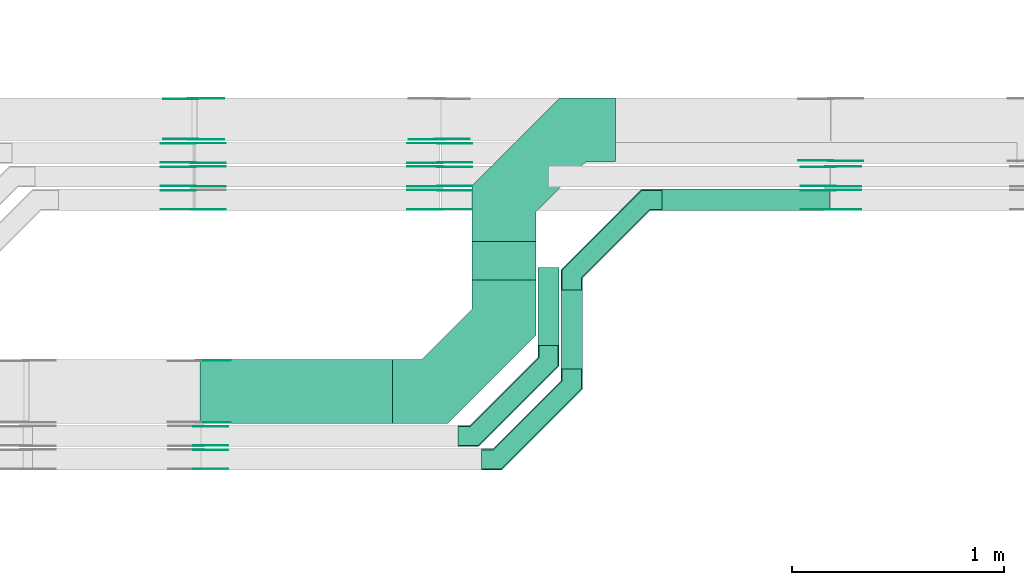
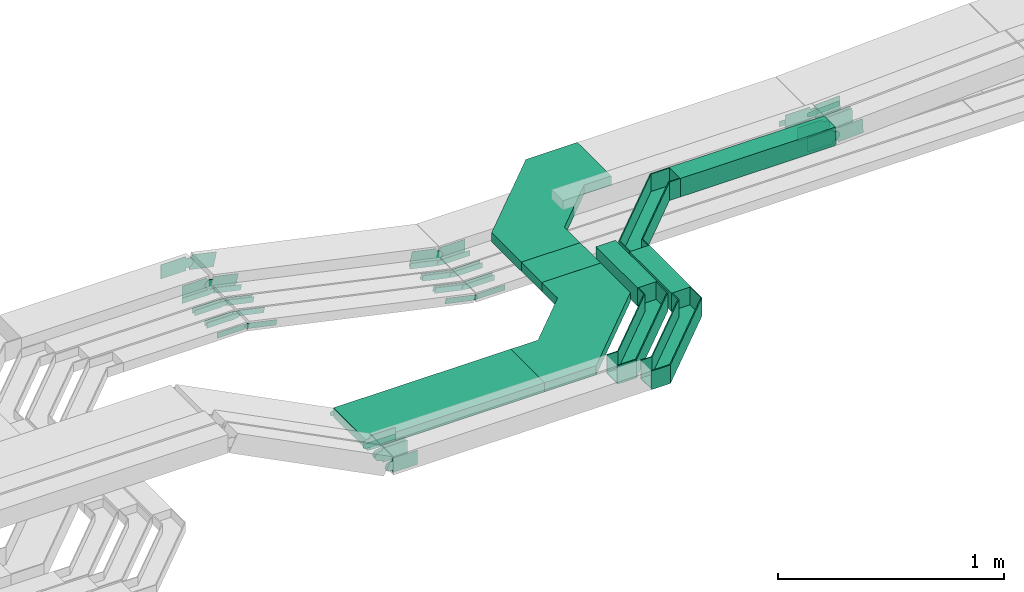
# One storey, part 15 of 32: 50 flow fittings, 5 flow segments.
"""IFC2X3 building model written with IfcOpenShell, lengths in millimetres."""

import ifcopenshell
import ifcopenshell.guid

model = None  # the IFC model being written
_history = None  # IfcOwnerHistory: only IFC2X3 demands one
_inside = {}  # id of a spatial element -> (the spatial element, [elements in it])
_under = {}  # id of a project, library or spatial element -> (it, [spatial elements below it])
_declared = {}  # id of a project -> (the project, [libraries it declares])
_typed = {}  # id of a type object -> (the type object, [elements of that type])
_made_of = {}  # id of a material, layer set ... -> (it, [elements and type objects made of it])


def new_model(schema):
    """Start an empty IFC model of exactly this schema.

    Asked for "IFC4X3", IfcOpenShell would pick the latest addendum, in which some entities
    have other attributes; the version numbers below select the first issue.
    IFC2X3 requires an IfcOwnerHistory on every rooted entity: one is made here for all.
    """
    global model, _history
    if schema == "IFC4X3":
        model = ifcopenshell.file(schema_version=(4, 3, 0, 0))
    else:
        model = ifcopenshell.file(schema=schema)
    _inside.clear()
    _under.clear()
    _declared.clear()
    _typed.clear()
    _made_of.clear()
    _history = None
    if model.schema == "IFC2X3":
        org = make("IfcOrganization", Name="unknown")
        user = make(
            "IfcPersonAndOrganization",
            ThePerson=make("IfcPerson", FamilyName="unknown"),
            TheOrganization=org,
        )
        app = make(
            "IfcApplication",
            ApplicationDeveloper=org,
            Version="unknown",
            ApplicationFullName="unknown",
            ApplicationIdentifier="unknown",
        )
        _history = make(
            "IfcOwnerHistory",
            OwningUser=user,
            OwningApplication=app,
            ChangeAction="ADDED",
            CreationDate=0,
        )
    return model


def make(cls, **values):
    """One entity of the class cls with the attributes given. An attribute that is None is left unset."""
    return model.create_entity(
        cls, **{name: value for name, value in values.items() if value is not None}
    )


def entity(cls, *values):
    """Any entity or typed value of the class cls, its attributes in the order of the schema. None: left unset."""
    e = model.create_entity(cls)
    for i, value in enumerate(values):
        if value is not None:
            e[i] = value
    return e


def rooted(cls, **values):
    """An entity with a GlobalId (a new one), such as an element, a storey or a relation."""
    return make(cls, GlobalId=ifcopenshell.guid.new(), OwnerHistory=_history, **values)


def si_unit(unit_type, name, prefix=None):
    """IfcSIUnit, for example si_unit("LENGTHUNIT", "METRE", prefix="MILLI")."""
    return make("IfcSIUnit", UnitType=unit_type, Prefix=prefix, Name=name)


def converted_unit(unit_type, name, factor, base, dimensions=None, offset=None):
    """IfcConversionBasedUnit, such as the inch: factor (a typed value) times the base unit."""
    return make(
        "IfcConversionBasedUnit"
        if offset is None
        else "IfcConversionBasedUnitWithOffset",
        ConversionOffset=offset,
        Dimensions=None
        if dimensions is None
        else entity("IfcDimensionalExponents", *dimensions),
        UnitType=unit_type,
        Name=name,
        ConversionFactor=make(
            "IfcMeasureWithUnit", ValueComponent=factor, UnitComponent=base
        ),
    )


def derived_unit(unit_type, elements):
    """IfcDerivedUnit: a product of units, each with its exponent."""
    return make(
        "IfcDerivedUnit",
        Elements=[
            make("IfcDerivedUnitElement", Unit=unit, Exponent=power)
            for unit, power in elements
        ],
        UnitType=unit_type,
    )


def assignment(units):
    """IfcUnitAssignment: the units of a project."""
    return None if units is None else make("IfcUnitAssignment", Units=units)


def point(xyz):
    """IfcCartesianPoint."""
    return None if xyz is None else make("IfcCartesianPoint", Coordinates=xyz)


def direction(xyz):
    """IfcDirection."""
    return None if xyz is None else make("IfcDirection", DirectionRatios=xyz)


def frame(location, z_axis=None, x_axis=None):
    """IfcAxis2Placement3D, a coordinate frame: its origin and axes. An axis left out is left unset."""
    return make(
        "IfcAxis2Placement3D",
        Location=point(location),
        Axis=direction(z_axis),
        RefDirection=direction(x_axis),
    )


def frame_2d(location, x_axis=None):
    """IfcAxis2Placement2D, a coordinate frame in the plane: its origin and x axis."""
    return make(
        "IfcAxis2Placement2D", Location=point(location), RefDirection=direction(x_axis)
    )


def origin():
    """The frame at (0, 0, 0) with its axes left unset."""
    return frame((0.0, 0.0, 0.0))


def origin_2d_with_axis():
    """The frame at (0, 0) in the plane with the x axis (1, 0) written out."""
    return frame_2d((0.0, 0.0), x_axis=(1.0, 0.0))


def place(relative_to, where):
    """IfcLocalPlacement: puts the frame where relative to a parent placement (None: the world)."""
    return make(
        "IfcLocalPlacement", PlacementRelTo=relative_to, RelativePlacement=where
    )


def context(
    kind, dimensions, precision=None, world=None, true_north=None, identifier=None
):
    """IfcGeometricRepresentationContext, for example the 3D "Model" context."""
    return make(
        "IfcGeometricRepresentationContext",
        ContextIdentifier=identifier,
        ContextType=kind,
        CoordinateSpaceDimension=dimensions,
        Precision=precision,
        WorldCoordinateSystem=world,
        TrueNorth=true_north,
    )


def subcontext(parent, identifier, kind, view, scale=None):
    """IfcGeometricRepresentationSubContext, for example "Body" below "Model"."""
    return make(
        "IfcGeometricRepresentationSubContext",
        ContextIdentifier=identifier,
        ContextType=kind,
        ParentContext=parent,
        TargetScale=scale,
        TargetView=view,
    )


def project(units=None, contexts=None):
    """IfcProject with its units and contexts."""
    return rooted(
        "IfcProject",
        Name="project",
        RepresentationContexts=contexts,
        UnitsInContext=assignment(units),
    )


def spatial(cls, under=None, at=None, **own):
    """A site, building, storey or space (cls), placed at a placement, below another one or the project."""
    s = rooted(cls, ObjectPlacement=at, **own)
    if under is not None:
        _under.setdefault(under.id(), (under, []))[1].append(s)
    return s


def polyline(points):
    """IfcPolyline through the points."""
    return make("IfcPolyline", Points=[point(p) for p in points])


def circle_curve(where, radius):
    """IfcCircle in the frame where."""
    return make("IfcCircle", Position=where, Radius=radius)


def parameter(value):
    """IfcParameterValue: where a trimmed curve begins or ends, as a parameter of its basis curve."""
    return model.create_entity("IfcParameterValue", value)


def trimmed(basis, trim1, trim2, sense, master):
    """IfcTrimmedCurve: the piece of a basis curve between two trims."""
    return make(
        "IfcTrimmedCurve",
        BasisCurve=basis,
        Trim1=trim1,
        Trim2=trim2,
        SenseAgreement=sense,
        MasterRepresentation=master,
    )


def segment(curve, same_sense, transition):
    """IfcCompositeCurveSegment."""
    return make(
        "IfcCompositeCurveSegment",
        Transition=transition,
        SameSense=same_sense,
        ParentCurve=curve,
    )


def composite_curve(segments, self_intersect=None):
    """IfcCompositeCurve: segments joined end to end."""
    return make("IfcCompositeCurve", Segments=segments, SelfIntersect=self_intersect)


def profile(cls, at=None, kind="AREA", **sizes):
    """A parametric profile (cls). Its sizes go by their IFC names, for example OverallWidth=200.0."""
    return make(cls, ProfileType=kind, Position=at, **sizes)


def rectangle(**sizes):
    """IfcRectangleProfileDef."""
    return profile("IfcRectangleProfileDef", **sizes)


def outline(outer, holes=None, kind="AREA"):
    """IfcArbitraryClosedProfileDef: a profile drawn as a closed curve; with holes, ...WithVoids."""
    if holes is None:
        return make("IfcArbitraryClosedProfileDef", ProfileType=kind, OuterCurve=outer)
    return make(
        "IfcArbitraryProfileDefWithVoids",
        ProfileType=kind,
        OuterCurve=outer,
        InnerCurves=holes,
    )


def extrude(swept, where, along, depth):
    """IfcExtrudedAreaSolid: the profile swept, set in the frame where, extruded along a direction by depth."""
    return make(
        "IfcExtrudedAreaSolid",
        SweptArea=swept,
        Position=where,
        ExtrudedDirection=direction(along),
        Depth=depth,
    )


def faces_of(points, faces, orient=None, outer=None):
    """IfcFace entities. A face is a list of loops; a loop is a list of indices into points, from 0.

    orient and outer hold one flag for each loop. By default every Orientation is true, the
    first loop of a face is its IfcFaceOuterBound and the others are IfcFaceBound.
    """
    made = []
    for i, loops in enumerate(faces):
        bounds = []
        for j, loop in enumerate(loops):
            is_outer = j == 0 if outer is None else outer[i][j]
            bounds.append(
                make(
                    "IfcFaceOuterBound" if is_outer else "IfcFaceBound",
                    Bound=make("IfcPolyLoop", Polygon=[points[k] for k in loop]),
                    Orientation=True if orient is None else orient[i][j],
                )
            )
        made.append(make("IfcFace", Bounds=bounds))
    return made


def faceted_brep(points, faces, orient=None, outer=None, voids=None):
    """IfcFacetedBrep: a solid bounded by flat faces; with voids (closed shells), ...WithVoids."""
    shared = [point(p) for p in points]
    hull = make("IfcClosedShell", CfsFaces=faces_of(shared, faces, orient, outer))
    if voids is None:
        return make("IfcFacetedBrep", Outer=hull)
    return make(
        "IfcFacetedBrepWithVoids",
        Outer=hull,
        Voids=[
            make(cls, CfsFaces=faces_of(shared, fs, o, b)) for cls, fs, o, b in voids
        ],
    )


def shape(context_of_items, identifier, shape_type, items):
    """IfcShapeRepresentation: the items that make up one representation, for example the "Body"."""
    return make(
        "IfcShapeRepresentation",
        ContextOfItems=context_of_items,
        RepresentationIdentifier=identifier,
        RepresentationType=shape_type,
        Items=items,
    )


def source(mapping_origin, context_of_items, identifier, shape_type, items):
    """IfcRepresentationMap: a shape defined once, which mapped items show again and again."""
    return make(
        "IfcRepresentationMap",
        MappingOrigin=mapping_origin,
        MappedRepresentation=shape(context_of_items, identifier, shape_type, items),
    )


def transform(
    local_origin,
    x_axis=None,
    y_axis=None,
    z_axis=None,
    scale=None,
    scale2=None,
    scale3=None,
    uniform=True,
):
    """IfcCartesianTransformationOperator3D, or its non-uniform kind. x_axis, y_axis, z_axis: its Axis1, 2, 3."""
    if uniform:
        return make(
            "IfcCartesianTransformationOperator3D",
            Axis1=direction(x_axis),
            Axis2=direction(y_axis),
            LocalOrigin=point(local_origin),
            Scale=scale,
            Axis3=direction(z_axis),
        )
    return make(
        "IfcCartesianTransformationOperator3DnonUniform",
        Axis1=direction(x_axis),
        Axis2=direction(y_axis),
        LocalOrigin=point(local_origin),
        Scale=scale,
        Axis3=direction(z_axis),
        Scale2=scale2,
        Scale3=scale3,
    )


def mapped(mapping_source, mapping_target):
    """IfcMappedItem: shows the shape of a source again, moved by a transform."""
    return make(
        "IfcMappedItem", MappingSource=mapping_source, MappingTarget=mapping_target
    )


def material(Name=None, Category=None):
    """IfcMaterial."""
    return make("IfcMaterial", Name=Name, Category=Category)


def made_of(thing, what):
    """Note that an element or type object is made of a material, layer set ...; save() writes the relation."""
    if what is not None:
        _made_of.setdefault(what.id(), (what, []))[1].append(thing)
    return thing


def type_object(cls, material=None, **own):
    """A type object (cls), such as IfcWallType, which elements share."""
    return made_of(rooted(cls, **own), material)


def type_shapes(of_type, sources):
    """Give a type object the sources (RepresentationMaps) that its elements show as mapped items."""
    of_type.RepresentationMaps = sources


def element(
    cls,
    number,
    at=None,
    inside=None,
    cuts=None,
    type_object=None,
    material=None,
    context=None,
    identifier="Body",
    shape_type=None,
    held_by="IfcProductDefinitionShape",
    body=None,
    shapes=None,
    **own,
):
    """One element of the class cls, such as IfcWall. Its Tag is "e" and its number.

    at: its placement. inside: the storey or other place that contains it. cuts: it is an
    opening in that element (IfcRelVoidsElement). A single representation is given by context,
    identifier, shape_type and body (its items); several are given by shapes. held_by: the class
    of the entity that holds the representations. save() writes the other relations.
    """
    e = rooted(cls, Tag="e%d" % number, ObjectPlacement=at, **own)
    if body is not None:
        shapes = [shape(context, identifier, shape_type, body)]
    if shapes is not None:
        e.Representation = make(held_by, Representations=shapes)
    if inside is not None:
        _inside.setdefault(inside.id(), (inside, []))[1].append(e)
    if cuts is not None:
        rooted(
            "IfcRelVoidsElement", RelatingBuildingElement=cuts, RelatedOpeningElement=e
        )
    if type_object is not None:
        _typed.setdefault(type_object.id(), (type_object, []))[1].append(e)
    return made_of(e, material)


def aggregate(whole, parts):
    """IfcRelAggregates: a whole, such as a stair, and the parts it consists of."""
    return rooted("IfcRelAggregates", RelatingObject=whole, RelatedObjects=parts)


def save(model, path):
    """Write the relations noted so far, then the file.

    IfcRelAggregates (storeys below a building ...), IfcRelContainedInSpatialStructure (elements
    in a storey), IfcRelDefinesByType, IfcRelAssociatesMaterial and IfcRelDeclares: one each for
    every whole, place, type object, material and project.
    """
    for whole, parts in _under.values():
        aggregate(whole, parts)
    for where, things in _inside.values():
        rooted(
            "IfcRelContainedInSpatialStructure",
            RelatedElements=things,
            RelatingStructure=where,
        )
    for kind, things in _typed.values():
        rooted("IfcRelDefinesByType", RelatedObjects=things, RelatingType=kind)
    for what, things in _made_of.values():
        rooted("IfcRelAssociatesMaterial", RelatedObjects=things, RelatingMaterial=what)
    for by, libraries in _declared.values():
        rooted("IfcRelDeclares", RelatingContext=by, RelatedDefinitions=libraries)
    model.write(path)


model = new_model("IFC2X3")

# Units and contexts
model_context = context("Model", 3, precision=0.01, world=origin(), true_north=direction((6.12303176911189e-17, 1.0)))
body_context = subcontext(model_context, "Body", "Model", "MODEL_VIEW")
ifc_project = project(units=[si_unit("LENGTHUNIT", "METRE", prefix="MILLI"), si_unit("AREAUNIT", "SQUARE_METRE"), si_unit("VOLUMEUNIT", "CUBIC_METRE"), converted_unit("PLANEANGLEUNIT", "DEGREE", entity("IfcRatioMeasure", 0.0174532925199433), si_unit("PLANEANGLEUNIT", "RADIAN"), dimensions=[0, 0, 0, 0, 0, 0, 0]), si_unit("MASSUNIT", "GRAM", prefix="KILO"), derived_unit("MASSDENSITYUNIT", [(si_unit("MASSUNIT", "GRAM", prefix="KILO"), 1), (si_unit("LENGTHUNIT", "METRE"), -3)]), derived_unit("MOMENTOFINERTIAUNIT", [(si_unit("LENGTHUNIT", "METRE"), 4)]), si_unit("TIMEUNIT", "SECOND"), si_unit("FREQUENCYUNIT", "HERTZ"), si_unit("THERMODYNAMICTEMPERATUREUNIT", "DEGREE_CELSIUS"), derived_unit("THERMALTRANSMITTANCEUNIT", [(si_unit("MASSUNIT", "GRAM", prefix="KILO"), 1), (si_unit("THERMODYNAMICTEMPERATUREUNIT", "KELVIN"), -1), (si_unit("TIMEUNIT", "SECOND"), -3)]), derived_unit("VOLUMETRICFLOWRATEUNIT", [(si_unit("LENGTHUNIT", "METRE"), 3), (si_unit("TIMEUNIT", "SECOND"), -1)]), derived_unit("MASSFLOWRATEUNIT", [(si_unit("MASSUNIT", "GRAM", prefix="KILO"), 1), (si_unit("TIMEUNIT", "SECOND"), -1)]), derived_unit("ROTATIONALFREQUENCYUNIT", [(si_unit("TIMEUNIT", "SECOND"), -1)]), si_unit("ELECTRICCURRENTUNIT", "AMPERE"), si_unit("ELECTRICVOLTAGEUNIT", "VOLT"), si_unit("POWERUNIT", "WATT"), si_unit("FORCEUNIT", "NEWTON", prefix="KILO"), si_unit("ILLUMINANCEUNIT", "LUX"), si_unit("LUMINOUSFLUXUNIT", "LUMEN"), si_unit("LUMINOUSINTENSITYUNIT", "CANDELA"), derived_unit("USERDEFINED", [(si_unit("MASSUNIT", "GRAM", prefix="KILO"), -1), (si_unit("LENGTHUNIT", "METRE"), -2), (si_unit("TIMEUNIT", "SECOND"), 3), (si_unit("LUMINOUSFLUXUNIT", "LUMEN"), 1)]), derived_unit("LINEARVELOCITYUNIT", [(si_unit("LENGTHUNIT", "METRE"), 1), (si_unit("TIMEUNIT", "SECOND"), -1)]), si_unit("PRESSUREUNIT", "PASCAL"), derived_unit("USERDEFINED", [(si_unit("LENGTHUNIT", "METRE"), -2), (si_unit("MASSUNIT", "GRAM", prefix="KILO"), 1), (si_unit("TIMEUNIT", "SECOND"), -2)]), derived_unit("LINEARFORCEUNIT", [(si_unit("MASSUNIT", "GRAM", prefix="KILO"), 1), (si_unit("LENGTHUNIT", "METRE"), 1), (si_unit("TIMEUNIT", "SECOND"), -2), (si_unit("LENGTHUNIT", "METRE"), -1)]), derived_unit("PLANARFORCEUNIT", [(si_unit("MASSUNIT", "GRAM", prefix="KILO"), 1), (si_unit("LENGTHUNIT", "METRE"), 1), (si_unit("TIMEUNIT", "SECOND"), -2), (si_unit("LENGTHUNIT", "METRE"), -2)])], contexts=[model_context])

# Site, building, storey
site_placement = place(None, origin())
site = spatial("IfcSite", under=ifc_project, at=site_placement, CompositionType="ELEMENT")
building_placement = place(site_placement, origin())
building = spatial("IfcBuilding", under=site, at=building_placement, CompositionType="ELEMENT")
storey_placement = place(building_placement, frame((0.0, 0.0, 8100.0)))
storey = spatial("IfcBuildingStorey", under=building, at=storey_placement, CompositionType="ELEMENT", Elevation=8100.0)

# Flow segments
cable_carrier_segment_type = type_object("IfcCableCarrierSegmentType", PredefinedType="CABLETRAYSEGMENT")
flow_segment_1_placement = place(storey_placement, frame((34739.92, 9645.0, 2749.28)))
element("IfcFlowSegment", 1, at=flow_segment_1_placement, inside=storey, type_object=cable_carrier_segment_type, context=body_context, shape_type="SweptSolid", body=[
    extrude(rectangle(XDim=791.634197765681, YDim=100.000000000001, at=origin_2d_with_axis()), frame((395.82, 50.0, 0.0)), (0.0, 0.0, 1.0), 99.9999999999989),
])
flow_segment_2_placement = place(storey_placement, frame((32562.96, 8642.05, 2750.02)))
element("IfcFlowSegment", 2, at=flow_segment_2_placement, inside=storey, type_object=cable_carrier_segment_type, context=body_context, shape_type="SweptSolid", body=[
    extrude(rectangle(XDim=905.362974416974, YDim=300.000000000001, at=origin_2d_with_axis()), frame((452.68, 150.0, 0.0)), (0.0, 0.0, 1.0), 50.0000000000016),
])
flow_segment_3_placement = place(storey_placement, frame((33844.32, 9318.05, 2750.02)))
element("IfcFlowSegment", 3, at=flow_segment_3_placement, inside=storey, type_object=cable_carrier_segment_type, context=body_context, shape_type="SweptSolid", body=[
    extrude(rectangle(XDim=180.951872357372, YDim=300.000000000001, at=origin_2d_with_axis()), frame((150.0, 90.48, 0.0), z_axis=(0.0, 0.0, 1.0), x_axis=(0.0, 1.0, 0.0)), (0.0, 0.0, 1.0), 49.9999999999995),
])
flow_segment_4_placement = place(storey_placement, frame((34153.92, 9008.45, 2750.01)))
element("IfcFlowSegment", 4, at=flow_segment_4_placement, inside=storey, type_object=cable_carrier_segment_type, context=body_context, shape_type="SweptSolid", body=[
    extrude(rectangle(XDim=366.546732922404, YDim=100.000000000003, at=origin_2d_with_axis()), frame((50.0, 183.27, 0.0), z_axis=(0.0, 0.0, 1.0), x_axis=(0.0, 1.0, 0.0)), (0.0, 0.0, 1.0), 99.9999999999968),
])
flow_segment_5_placement = place(storey_placement, frame((34263.92, 8898.45, 2749.28)))
element("IfcFlowSegment", 5, at=flow_segment_5_placement, inside=storey, type_object=cable_carrier_segment_type, context=body_context, shape_type="SweptSolid", body=[
    extrude(rectangle(XDim=370.546732922424, YDim=100.000000000003, at=origin_2d_with_axis()), frame((50.0, 185.27, 0.0), z_axis=(0.0, 0.0, 1.0), x_axis=(0.0, 1.0, 0.0)), (0.0, 0.0, 1.0), 99.9999999999989),
])

# Flow fittings
ifc_material_1 = material()
cable_carrier_fitting_type_1 = type_object("IfcCableCarrierFittingType", Name="470_DKC_G5_Sheet horizontal bend:-", PredefinedType="NOTDEFINED", material=ifc_material_1)
shared_shape_1 = source(origin(), body_context, "Body", "SweptSolid", [
    extrude(outline(polyline([(-313.25, -362.75), (-50.12, -362.75), (362.75, 50.12), (362.75, 313.25), (62.75, 313.25), (62.75, 174.38), (-174.38, -62.75), (-313.25, -62.75), (-313.25, -362.75)])), frame((-212.75, 212.75, -25.0)), (0.0, 0.0, 1.0), 50.0000000000003),
])
type_shapes(cable_carrier_fitting_type_1, [shared_shape_1])
flow_fitting_1_placement = place(storey_placement, frame((33994.32, 8792.05, 2775.02)))
element("IfcFlowFitting", 6, at=flow_fitting_1_placement, inside=storey, type_object=cable_carrier_fitting_type_1, material=ifc_material_1, Name="470_DKC_G5_Sheet horizontal bend:-", ObjectType="470_DKC_G5_Sheet horizontal bend:-", context=body_context, shape_type="MappedRepresentation", body=[
    mapped(shared_shape_1, transform((0.0, 0.0, 0.0), scale=1.0)),
])
flow_fitting_2_placement = place(storey_placement, frame((33994.32, 10025.0, 2775.02), z_axis=(0.0, 0.0, 1.0), x_axis=(-1.0, 0.0, 0.0)))
element("IfcFlowFitting", 7, at=flow_fitting_2_placement, inside=storey, type_object=cable_carrier_fitting_type_1, material=ifc_material_1, Name="470_DKC_G5_Sheet horizontal bend:-", ObjectType="470_DKC_G5_Sheet horizontal bend:-", context=body_context, shape_type="MappedRepresentation", body=[
    mapped(shared_shape_1, transform((0.0, 0.0, 0.0), scale=1.0)),
])
cable_carrier_fitting_type_2 = type_object("IfcCableCarrierFittingType", Name="470_DKC_G5_Sheet horizontal bend:-", PredefinedType="NOTDEFINED", material=ifc_material_1)
shared_shape_2 = source(origin(), body_context, "Body", "Brep", [
    faceted_brep([(-426.0, -50.0, -50.0), (-426.0, -50.0, 50.0), (-426.0, -45.0, 50.0), (-426.0, -45.0, -45.0), (-426.0, 45.0, -45.0), (-426.0, 45.0, 50.0), (-426.0, 50.0, 50.0), (-426.0, 50.0, -50.0), (50.0, 426.0, -50.0), (-50.0, 426.0, -50.0), (-50.0, 426.0, 50.0), (-45.0, 426.0, 50.0), (-45.0, 426.0, -45.0), (45.0, 426.0, -45.0), (45.0, 426.0, 50.0), (50.0, 426.0, 50.0), (-329.29, -50.0, -50.0), (-329.29, -50.0, 50.0), (50.0, 329.29, 50.0), (45.0, 331.36, 50.0), (-331.36, -45.0, 50.0), (-331.36, -45.0, -45.0), (45.0, 331.36, -45.0), (-45.0, 368.64, -45.0), (-368.64, 45.0, -45.0), (-368.64, 45.0, 50.0), (-45.0, 368.64, 50.0), (-50.0, 370.71, 50.0), (-370.71, 50.0, 50.0), (-370.71, 50.0, -50.0), (-50.0, 370.71, -50.0), (50.0, 329.29, -50.0)], [[[0, 1, 2, 3, 4, 5, 6, 7]], [[8, 9, 10, 11, 12, 13, 14, 15]], [[1, 0, 16, 17]], [[2, 1, 17, 18, 15, 14, 19, 20]], [[3, 2, 20, 21]], [[4, 3, 21, 22, 13, 12, 23, 24]], [[5, 4, 24, 25]], [[6, 5, 25, 26, 11, 10, 27, 28]], [[7, 6, 28, 29]], [[0, 7, 29, 30, 9, 8, 31, 16]], [[17, 16, 31, 18]], [[21, 20, 19, 22]], [[25, 24, 23, 26]], [[29, 28, 27, 30]], [[18, 31, 8, 15]], [[22, 19, 14, 13]], [[26, 23, 12, 11]], [[30, 27, 10, 9]]]),
])
type_shapes(cable_carrier_fitting_type_2, [shared_shape_2])
for number, where, name in (
    (8, (34203.92, 8582.45, 2800.01), "470_DKC_G5_Sheet horizontal bend:-"),
    (9, (34313.92, 8472.45, 2799.28), "470_DKC_G5_Sheet horizontal bend:-"),
):
    element("IfcFlowFitting", number, at=place(storey_placement, frame(where)), inside=storey, type_object=cable_carrier_fitting_type_2, material=ifc_material_1, Name=name, ObjectType="470_DKC_G5_Sheet horizontal bend:-", context=body_context, shape_type="MappedRepresentation", body=[
        mapped(shared_shape_2, transform((0.0, 0.0, 0.0), scale=1.0)),
    ])
flow_fitting_3_placement = place(storey_placement, frame((34313.92, 9695.0, 2799.28), z_axis=(0.0, 0.0, 1.0), x_axis=(-1.0, 0.0, 0.0)))
element("IfcFlowFitting", 10, at=flow_fitting_3_placement, inside=storey, type_object=cable_carrier_fitting_type_2, material=ifc_material_1, Name="470_DKC_G5_Sheet horizontal bend:-", ObjectType="470_DKC_G5_Sheet horizontal bend:-", context=body_context, shape_type="MappedRepresentation", body=[
    mapped(shared_shape_2, transform((0.0, 0.0, 0.0), scale=1.0)),
])
ifc_material_2 = material(Name="G")
cable_carrier_fitting_type_3 = type_object("IfcCableCarrierFittingType", PredefinedType="NOTDEFINED", material=ifc_material_2)
shared_shape_3 = source(origin(), body_context, "Body", "SweptSolid", [
    extrude(outline(composite_curve([segment(trimmed(circle_curve(frame_2d((-44.59, 0.0), x_axis=(1.0, 0.0)), 12.5), [parameter(90.0000000000007)], [parameter(270.0)], True, "PARAMETER"), True, "CONTINUOUS"), segment(polyline([(-44.59, -12.5), (-33.09, -12.5)]), True, "CONTINUOUS"), segment(polyline([(-33.09, -12.5), (-31.23, -14.5)]), True, "CONTINUOUS"), segment(polyline([(-31.23, -14.5), (108.91, -14.5)]), True, "CONTINUOUS"), segment(polyline([(108.91, -14.5), (108.91, 14.5)]), True, "CONTINUOUS"), segment(polyline([(108.91, 14.5), (-31.23, 14.5)]), True, "CONTINUOUS"), segment(polyline([(-31.23, 14.5), (-33.09, 12.5)]), True, "CONTINUOUS"), segment(polyline([(-33.09, 12.5), (-44.59, 12.5)]), True, "CONTINUOUS")], self_intersect=False)), frame((44.59, 0.0, 0.0), z_axis=(0.0, 0.0, -1.0), x_axis=(1.0, 0.0, 0.0)), (0.0, 0.0, -1.0), 2.0),
])
type_shapes(cable_carrier_fitting_type_3, [shared_shape_3])
flow_fitting_4_placement = place(storey_placement, frame((33692.72, 9740.46, 2571.63), z_axis=(0.0, 1.0, 0.0), x_axis=(-0.977059422663225, 0.0, 0.212966862645354)))
element("IfcFlowFitting", 11, at=flow_fitting_4_placement, inside=storey, type_object=cable_carrier_fitting_type_3, material=ifc_material_2, context=body_context, shape_type="MappedRepresentation", body=[
    mapped(shared_shape_3, transform((0.0, 0.0, 0.0), scale=1.0)),
])
cable_carrier_fitting_type_4 = type_object("IfcCableCarrierFittingType", PredefinedType="NOTDEFINED", material=ifc_material_2)
type_shapes(cable_carrier_fitting_type_4, [shared_shape_3])
for number, where, z_axis, x_axis in (
    (12, (33692.72, 9651.54, 2571.63), (0.0, -1.0, 0.0), (1.0, 0.0, 0.0)),
    (13, (32530.31, 9651.54, 2825.0), (0.0, -1.0, 0.0), (-1.0, 0.0, 0.0)),
):
    element("IfcFlowFitting", number, at=place(storey_placement, frame(where, z_axis=z_axis, x_axis=x_axis)), inside=storey, type_object=cable_carrier_fitting_type_4, material=ifc_material_2, context=body_context, shape_type="MappedRepresentation", body=[
        mapped(shared_shape_3, transform((0.0, 0.0, 0.0), scale=1.0)),
    ])
flow_fitting_5_placement = place(storey_placement, frame((33692.72, 9850.46, 2571.32), z_axis=(0.0, 1.0, 0.0), x_axis=(-0.977004473697579, 0.0, 0.21321880398998)))
element("IfcFlowFitting", 14, at=flow_fitting_5_placement, inside=storey, type_object=cable_carrier_fitting_type_3, material=ifc_material_2, context=body_context, shape_type="MappedRepresentation", body=[
    mapped(shared_shape_3, transform((0.0, 0.0, 0.0), scale=1.0)),
])
flow_fitting_6_placement = place(storey_placement, frame((33692.72, 9761.54, 2571.32), z_axis=(0.0, -1.0, 0.0), x_axis=(1.0, 0.0, 0.0)))
element("IfcFlowFitting", 15, at=flow_fitting_6_placement, inside=storey, type_object=cable_carrier_fitting_type_4, material=ifc_material_2, context=body_context, shape_type="MappedRepresentation", body=[
    mapped(shared_shape_3, transform((0.0, 0.0, 0.0), scale=1.0)),
])
flow_fitting_7_placement = place(storey_placement, frame((32530.31, 9850.46, 2825.0), z_axis=(0.0, 1.0, 0.0), x_axis=(0.977004473697579, 0.0, -0.21321880398998)))
element("IfcFlowFitting", 16, at=flow_fitting_7_placement, inside=storey, type_object=cable_carrier_fitting_type_3, material=ifc_material_2, context=body_context, shape_type="MappedRepresentation", body=[
    mapped(shared_shape_3, transform((0.0, 0.0, 0.0), scale=1.0)),
])
flow_fitting_8_placement = place(storey_placement, frame((32530.31, 9761.54, 2825.0), z_axis=(0.0, -1.0, 0.0), x_axis=(-1.0, 0.0, 0.0)))
element("IfcFlowFitting", 17, at=flow_fitting_8_placement, inside=storey, type_object=cable_carrier_fitting_type_4, material=ifc_material_2, context=body_context, shape_type="MappedRepresentation", body=[
    mapped(shared_shape_3, transform((0.0, 0.0, 0.0), scale=1.0)),
])
flow_fitting_9_placement = place(storey_placement, frame((33692.72, 9960.46, 2569.93), z_axis=(0.0, 1.0, 0.0), x_axis=(-0.976759892794402, 0.0, 0.214336445403643)))
element("IfcFlowFitting", 18, at=flow_fitting_9_placement, inside=storey, type_object=cable_carrier_fitting_type_3, material=ifc_material_2, context=body_context, shape_type="MappedRepresentation", body=[
    mapped(shared_shape_3, transform((0.0, 0.0, 0.0), scale=1.0)),
])
flow_fitting_10_placement = place(storey_placement, frame((33692.72, 9871.54, 2569.93), z_axis=(0.0, -1.0, 0.0), x_axis=(1.0, 0.0, 0.0)))
element("IfcFlowFitting", 19, at=flow_fitting_10_placement, inside=storey, type_object=cable_carrier_fitting_type_4, material=ifc_material_2, context=body_context, shape_type="MappedRepresentation", body=[
    mapped(shared_shape_3, transform((0.0, 0.0, 0.0), scale=1.0)),
])
flow_fitting_11_placement = place(storey_placement, frame((32530.31, 9960.46, 2825.0), z_axis=(0.0, 1.0, 0.0), x_axis=(0.976759892794402, 0.0, -0.214336445403643)))
element("IfcFlowFitting", 20, at=flow_fitting_11_placement, inside=storey, type_object=cable_carrier_fitting_type_3, material=ifc_material_2, context=body_context, shape_type="MappedRepresentation", body=[
    mapped(shared_shape_3, transform((0.0, 0.0, 0.0), scale=1.0)),
])
flow_fitting_12_placement = place(storey_placement, frame((32530.31, 9871.54, 2825.0), z_axis=(0.0, -1.0, 0.0), x_axis=(-1.0, 0.0, 0.0)))
element("IfcFlowFitting", 21, at=flow_fitting_12_placement, inside=storey, type_object=cable_carrier_fitting_type_4, material=ifc_material_2, context=body_context, shape_type="MappedRepresentation", body=[
    mapped(shared_shape_3, transform((0.0, 0.0, 0.0), scale=1.0)),
])
for number, where, z_axis, x_axis in (
    (22, (32555.01, 8646.59, 2775.02), (0.0, -1.0, 0.0), (1.0, 0.0, 0.0)),
    (23, (35533.92, 9879.54, 2775.02), (0.0, -1.0, 0.0), (0.998721383285711, 0.0, 0.0505529283808162)),
):
    element("IfcFlowFitting", number, at=place(storey_placement, frame(where, z_axis=z_axis, x_axis=x_axis)), inside=storey, type_object=cable_carrier_fitting_type_3, material=ifc_material_2, context=body_context, shape_type="MappedRepresentation", body=[
        mapped(shared_shape_3, transform((0.0, 0.0, 0.0), scale=1.0)),
    ])
cable_carrier_fitting_type_5 = type_object("IfcCableCarrierFittingType", PredefinedType="NOTDEFINED", material=ifc_material_2)
shared_shape_4 = source(origin(), body_context, "Body", "SweptSolid", [
    extrude(outline(composite_curve([segment(trimmed(circle_curve(frame_2d((-44.59, 0.0), x_axis=(1.0, 0.0)), 12.5), [parameter(90.0000000000007)], [parameter(270.0)], True, "PARAMETER"), True, "CONTINUOUS"), segment(polyline([(-44.59, -12.5), (-33.09, -12.5)]), True, "CONTINUOUS"), segment(polyline([(-33.09, -12.5), (-31.23, -14.5)]), True, "CONTINUOUS"), segment(polyline([(-31.23, -14.5), (108.91, -14.5)]), True, "CONTINUOUS"), segment(polyline([(108.91, -14.5), (108.91, 14.5)]), True, "CONTINUOUS"), segment(polyline([(108.91, 14.5), (-31.23, 14.5)]), True, "CONTINUOUS"), segment(polyline([(-31.23, 14.5), (-33.09, 12.5)]), True, "CONTINUOUS"), segment(polyline([(-33.09, 12.5), (-44.59, 12.5)]), True, "CONTINUOUS")], self_intersect=False)), frame((44.59, 0.0, 0.0)), (0.0, 0.0, 1.0), 2.0),
])
type_shapes(cable_carrier_fitting_type_5, [shared_shape_4])
flow_fitting_13_placement = place(storey_placement, frame((33692.72, 9649.54, 2571.63), z_axis=(0.0, -1.0, 0.0), x_axis=(-0.977059422663225, 0.0, 0.212966862645354)))
element("IfcFlowFitting", 24, at=flow_fitting_13_placement, inside=storey, type_object=cable_carrier_fitting_type_5, material=ifc_material_2, context=body_context, shape_type="MappedRepresentation", body=[
    mapped(shared_shape_4, transform((0.0, 0.0, 0.0), scale=1.0)),
])
cable_carrier_fitting_type_6 = type_object("IfcCableCarrierFittingType", PredefinedType="NOTDEFINED", material=ifc_material_2)
type_shapes(cable_carrier_fitting_type_6, [shared_shape_4])
flow_fitting_14_placement = place(storey_placement, frame((33692.72, 9738.46, 2571.63), z_axis=(0.0, 1.0, 0.0), x_axis=(1.0, 0.0, 0.0)))
element("IfcFlowFitting", 25, at=flow_fitting_14_placement, inside=storey, type_object=cable_carrier_fitting_type_6, material=ifc_material_2, context=body_context, shape_type="MappedRepresentation", body=[
    mapped(shared_shape_4, transform((0.0, 0.0, 0.0), scale=1.0)),
])
flow_fitting_15_placement = place(storey_placement, frame((32530.31, 9649.54, 2825.0), z_axis=(0.0, -1.0, 0.0), x_axis=(0.977059422663225, 0.0, -0.212966862645354)))
element("IfcFlowFitting", 26, at=flow_fitting_15_placement, inside=storey, type_object=cable_carrier_fitting_type_5, material=ifc_material_2, context=body_context, shape_type="MappedRepresentation", body=[
    mapped(shared_shape_4, transform((0.0, 0.0, 0.0), scale=1.0)),
])
flow_fitting_16_placement = place(storey_placement, frame((32530.31, 9738.46, 2825.0), z_axis=(0.0, 1.0, 0.0), x_axis=(-1.0, 0.0, 0.0)))
element("IfcFlowFitting", 27, at=flow_fitting_16_placement, inside=storey, type_object=cable_carrier_fitting_type_6, material=ifc_material_2, context=body_context, shape_type="MappedRepresentation", body=[
    mapped(shared_shape_4, transform((0.0, 0.0, 0.0), scale=1.0)),
])
flow_fitting_17_placement = place(storey_placement, frame((33692.72, 9759.54, 2571.32), z_axis=(0.0, -1.0, 0.0), x_axis=(-0.977004473697579, 0.0, 0.21321880398998)))
element("IfcFlowFitting", 28, at=flow_fitting_17_placement, inside=storey, type_object=cable_carrier_fitting_type_5, material=ifc_material_2, context=body_context, shape_type="MappedRepresentation", body=[
    mapped(shared_shape_4, transform((0.0, 0.0, 0.0), scale=1.0)),
])
flow_fitting_18_placement = place(storey_placement, frame((33692.72, 9848.46, 2571.32), z_axis=(0.0, 1.0, 0.0), x_axis=(1.0, 0.0, 0.0)))
element("IfcFlowFitting", 29, at=flow_fitting_18_placement, inside=storey, type_object=cable_carrier_fitting_type_6, material=ifc_material_2, context=body_context, shape_type="MappedRepresentation", body=[
    mapped(shared_shape_4, transform((0.0, 0.0, 0.0), scale=1.0)),
])
flow_fitting_19_placement = place(storey_placement, frame((32530.31, 9759.54, 2825.0), z_axis=(0.0, -1.0, 0.0), x_axis=(0.977004473697579, 0.0, -0.21321880398998)))
element("IfcFlowFitting", 30, at=flow_fitting_19_placement, inside=storey, type_object=cable_carrier_fitting_type_5, material=ifc_material_2, context=body_context, shape_type="MappedRepresentation", body=[
    mapped(shared_shape_4, transform((0.0, 0.0, 0.0), scale=1.0)),
])
flow_fitting_20_placement = place(storey_placement, frame((32530.31, 9848.46, 2825.0), z_axis=(0.0, 1.0, 0.0), x_axis=(-1.0, 0.0, 0.0)))
element("IfcFlowFitting", 31, at=flow_fitting_20_placement, inside=storey, type_object=cable_carrier_fitting_type_6, material=ifc_material_2, context=body_context, shape_type="MappedRepresentation", body=[
    mapped(shared_shape_4, transform((0.0, 0.0, 0.0), scale=1.0)),
])
flow_fitting_21_placement = place(storey_placement, frame((33692.72, 9869.54, 2569.93), z_axis=(0.0, -1.0, 0.0), x_axis=(-0.976759892794402, 0.0, 0.214336445403643)))
element("IfcFlowFitting", 32, at=flow_fitting_21_placement, inside=storey, type_object=cable_carrier_fitting_type_5, material=ifc_material_2, context=body_context, shape_type="MappedRepresentation", body=[
    mapped(shared_shape_4, transform((0.0, 0.0, 0.0), scale=1.0)),
])
flow_fitting_22_placement = place(storey_placement, frame((33692.72, 9958.46, 2569.93), z_axis=(0.0, 1.0, 0.0), x_axis=(1.0, 0.0, 0.0)))
element("IfcFlowFitting", 33, at=flow_fitting_22_placement, inside=storey, type_object=cable_carrier_fitting_type_6, material=ifc_material_2, context=body_context, shape_type="MappedRepresentation", body=[
    mapped(shared_shape_4, transform((0.0, 0.0, 0.0), scale=1.0)),
])
flow_fitting_23_placement = place(storey_placement, frame((32530.31, 9869.54, 2825.0), z_axis=(0.0, -1.0, 0.0), x_axis=(0.976759892794402, 0.0, -0.214336445403643)))
element("IfcFlowFitting", 34, at=flow_fitting_23_placement, inside=storey, type_object=cable_carrier_fitting_type_5, material=ifc_material_2, context=body_context, shape_type="MappedRepresentation", body=[
    mapped(shared_shape_4, transform((0.0, 0.0, 0.0), scale=1.0)),
])
flow_fitting_24_placement = place(storey_placement, frame((32530.31, 9958.46, 2825.0), z_axis=(0.0, 1.0, 0.0), x_axis=(-1.0, 0.0, 0.0)))
element("IfcFlowFitting", 35, at=flow_fitting_24_placement, inside=storey, type_object=cable_carrier_fitting_type_6, material=ifc_material_2, context=body_context, shape_type="MappedRepresentation", body=[
    mapped(shared_shape_4, transform((0.0, 0.0, 0.0), scale=1.0)),
])
flow_fitting_25_placement = place(storey_placement, frame((32555.01, 8937.51, 2775.02), z_axis=(0.0, 1.0, 0.0), x_axis=(1.0, 0.0, 0.0)))
element("IfcFlowFitting", 36, at=flow_fitting_25_placement, inside=storey, type_object=cable_carrier_fitting_type_5, material=ifc_material_2, context=body_context, shape_type="MappedRepresentation", body=[
    mapped(shared_shape_4, transform((0.0, 0.0, 0.0), scale=1.0)),
])
flow_fitting_26_placement = place(storey_placement, frame((35533.92, 9881.54, 2775.02), z_axis=(0.0, -1.0, 0.0), x_axis=(-1.0, 0.0, 0.0)))
element("IfcFlowFitting", 37, at=flow_fitting_26_placement, inside=storey, type_object=cable_carrier_fitting_type_6, material=ifc_material_2, context=body_context, shape_type="MappedRepresentation", body=[
    mapped(shared_shape_4, transform((0.0, 0.0, 0.0), scale=1.0)),
])
cable_carrier_fitting_type_7 = type_object("IfcCableCarrierFittingType", PredefinedType="NOTDEFINED", material=ifc_material_2)
shared_shape_5 = source(origin(), body_context, "Body", "SweptSolid", [
    extrude(outline(composite_curve([segment(trimmed(circle_curve(frame_2d((-41.47, 0.0), x_axis=(1.0, 0.0)), 25.0), [parameter(90.0000000000007)], [parameter(270.0)], True, "PARAMETER"), True, "CONTINUOUS"), segment(polyline([(-41.47, -25.0), (-29.97, -25.0)]), True, "CONTINUOUS"), segment(polyline([(-29.97, -25.0), (-28.1, -38.5)]), True, "CONTINUOUS"), segment(polyline([(-28.1, -38.5), (99.53, -38.5)]), True, "CONTINUOUS"), segment(polyline([(99.53, -38.5), (99.53, 38.5)]), True, "CONTINUOUS"), segment(polyline([(99.53, 38.5), (-28.1, 38.5)]), True, "CONTINUOUS"), segment(polyline([(-28.1, 38.5), (-29.97, 25.0)]), True, "CONTINUOUS"), segment(polyline([(-29.97, 25.0), (-41.47, 25.0)]), True, "CONTINUOUS")], self_intersect=False)), frame((41.47, 0.0, 0.0), z_axis=(0.0, 0.0, -1.0), x_axis=(1.0, 0.0, 0.0)), (0.0, 0.0, -1.0), 2.0),
])
type_shapes(cable_carrier_fitting_type_7, [shared_shape_5])
for number, where, z_axis, x_axis in (
    (38, (32555.01, 8428.99, 2799.28), (0.0, -1.0, 0.0), (1.0, 0.0, 0.0)),
    (39, (32555.01, 8538.99, 2800.01), (0.0, -1.0, 0.0), (1.0, 0.0, 0.0)),
):
    element("IfcFlowFitting", number, at=place(storey_placement, frame(where, z_axis=z_axis, x_axis=x_axis)), inside=storey, type_object=cable_carrier_fitting_type_7, material=ifc_material_2, context=body_context, shape_type="MappedRepresentation", body=[
        mapped(shared_shape_5, transform((0.0, 0.0, 0.0), scale=1.0)),
    ])
cable_carrier_fitting_type_8 = type_object("IfcCableCarrierFittingType", PredefinedType="NOTDEFINED", material=ifc_material_2)
type_shapes(cable_carrier_fitting_type_8, [shared_shape_5])
flow_fitting_27_placement = place(storey_placement, frame((35533.92, 9649.54, 2799.28), z_axis=(0.0, -1.0, 0.0), x_axis=(0.998721383285712, 0.0, 0.0505529283807962)))
element("IfcFlowFitting", 40, at=flow_fitting_27_placement, inside=storey, type_object=cable_carrier_fitting_type_8, material=ifc_material_2, context=body_context, shape_type="MappedRepresentation", body=[
    mapped(shared_shape_5, transform((0.0, 0.0, 0.0), scale=1.0)),
])
flow_fitting_28_placement = place(storey_placement, frame((35533.92, 9738.46, 2799.28), z_axis=(0.0, 1.0, 0.0), x_axis=(-1.0, 0.0, 0.0)))
element("IfcFlowFitting", 41, at=flow_fitting_28_placement, inside=storey, type_object=cable_carrier_fitting_type_7, material=ifc_material_2, context=body_context, shape_type="MappedRepresentation", body=[
    mapped(shared_shape_5, transform((0.0, 0.0, 0.0), scale=1.0)),
])
flow_fitting_29_placement = place(storey_placement, frame((35533.92, 9759.54, 2800.01), z_axis=(0.0, -1.0, 0.0), x_axis=(0.998721383285712, 0.0, 0.0505529283807962)))
element("IfcFlowFitting", 42, at=flow_fitting_29_placement, inside=storey, type_object=cable_carrier_fitting_type_8, material=ifc_material_2, context=body_context, shape_type="MappedRepresentation", body=[
    mapped(shared_shape_5, transform((0.0, 0.0, 0.0), scale=1.0)),
])
for number, where, z_axis, x_axis in (
    (43, (35533.92, 9848.46, 2800.01), (0.0, 1.0, 0.0), (-1.0, 0.0, 0.0)),
    (44, (33692.72, 9981.54, 2597.39), (0.0, -1.0, 0.0), (1.0, 0.0, 0.0)),
):
    element("IfcFlowFitting", number, at=place(storey_placement, frame(where, z_axis=z_axis, x_axis=x_axis)), inside=storey, type_object=cable_carrier_fitting_type_7, material=ifc_material_2, context=body_context, shape_type="MappedRepresentation", body=[
        mapped(shared_shape_5, transform((0.0, 0.0, 0.0), scale=1.0)),
    ])
flow_fitting_30_placement = place(storey_placement, frame((32530.31, 10170.46, 2850.0), z_axis=(0.0, 1.0, 0.0), x_axis=(0.977192506439547, 0.0, -0.212355375157765)))
element("IfcFlowFitting", 45, at=flow_fitting_30_placement, inside=storey, type_object=cable_carrier_fitting_type_8, material=ifc_material_2, context=body_context, shape_type="MappedRepresentation", body=[
    mapped(shared_shape_5, transform((0.0, 0.0, 0.0), scale=1.0)),
])
flow_fitting_31_placement = place(storey_placement, frame((32530.31, 9981.54, 2850.0), z_axis=(0.0, -1.0, 0.0), x_axis=(-1.0, 0.0, 0.0)))
element("IfcFlowFitting", 46, at=flow_fitting_31_placement, inside=storey, type_object=cable_carrier_fitting_type_7, material=ifc_material_2, context=body_context, shape_type="MappedRepresentation", body=[
    mapped(shared_shape_5, transform((0.0, 0.0, 0.0), scale=1.0)),
])
cable_carrier_fitting_type_9 = type_object("IfcCableCarrierFittingType", PredefinedType="NOTDEFINED", material=ifc_material_2)
shared_shape_6 = source(origin(), body_context, "Body", "SweptSolid", [
    extrude(outline(composite_curve([segment(trimmed(circle_curve(frame_2d((-41.47, 0.0), x_axis=(1.0, 0.0)), 25.0), [parameter(90.0000000000007)], [parameter(270.0)], True, "PARAMETER"), True, "CONTINUOUS"), segment(polyline([(-41.47, -25.0), (-29.97, -25.0)]), True, "CONTINUOUS"), segment(polyline([(-29.97, -25.0), (-28.1, -38.5)]), True, "CONTINUOUS"), segment(polyline([(-28.1, -38.5), (99.53, -38.5)]), True, "CONTINUOUS"), segment(polyline([(99.53, -38.5), (99.53, 38.5)]), True, "CONTINUOUS"), segment(polyline([(99.53, 38.5), (-28.1, 38.5)]), True, "CONTINUOUS"), segment(polyline([(-28.1, 38.5), (-29.97, 25.0)]), True, "CONTINUOUS"), segment(polyline([(-29.97, 25.0), (-41.47, 25.0)]), True, "CONTINUOUS")], self_intersect=False)), frame((41.47, 0.0, 0.0)), (0.0, 0.0, 1.0), 2.0),
])
type_shapes(cable_carrier_fitting_type_9, [shared_shape_6])
for number, where, z_axis, x_axis in (
    (47, (32555.01, 8515.91, 2799.28), (0.0, 1.0, 0.0), (1.0, 0.0, 0.0)),
    (48, (32555.01, 8625.91, 2800.01), (0.0, 1.0, 0.0), (1.0, 0.0, 0.0)),
):
    element("IfcFlowFitting", number, at=place(storey_placement, frame(where, z_axis=z_axis, x_axis=x_axis)), inside=storey, type_object=cable_carrier_fitting_type_9, material=ifc_material_2, context=body_context, shape_type="MappedRepresentation", body=[
        mapped(shared_shape_6, transform((0.0, 0.0, 0.0), scale=1.0)),
    ])
cable_carrier_fitting_type_10 = type_object("IfcCableCarrierFittingType", PredefinedType="NOTDEFINED", material=ifc_material_2)
type_shapes(cable_carrier_fitting_type_10, [shared_shape_6])
flow_fitting_32_placement = place(storey_placement, frame((35533.92, 9740.46, 2799.28), z_axis=(0.0, 1.0, 0.0), x_axis=(0.998721383285712, 0.0, 0.0505529283807962)))
element("IfcFlowFitting", 49, at=flow_fitting_32_placement, inside=storey, type_object=cable_carrier_fitting_type_10, material=ifc_material_2, context=body_context, shape_type="MappedRepresentation", body=[
    mapped(shared_shape_6, transform((0.0, 0.0, 0.0), scale=1.0)),
])
flow_fitting_33_placement = place(storey_placement, frame((35533.92, 9651.54, 2799.28), z_axis=(0.0, -1.0, 0.0), x_axis=(-1.0, 0.0, 0.0)))
element("IfcFlowFitting", 50, at=flow_fitting_33_placement, inside=storey, type_object=cable_carrier_fitting_type_9, material=ifc_material_2, context=body_context, shape_type="MappedRepresentation", body=[
    mapped(shared_shape_6, transform((0.0, 0.0, 0.0), scale=1.0)),
])
flow_fitting_34_placement = place(storey_placement, frame((35533.92, 9850.46, 2800.01), z_axis=(0.0, 1.0, 0.0), x_axis=(0.998721383285712, 0.0, 0.0505529283807962)))
element("IfcFlowFitting", 51, at=flow_fitting_34_placement, inside=storey, type_object=cable_carrier_fitting_type_10, material=ifc_material_2, context=body_context, shape_type="MappedRepresentation", body=[
    mapped(shared_shape_6, transform((0.0, 0.0, 0.0), scale=1.0)),
])
flow_fitting_35_placement = place(storey_placement, frame((35533.92, 9761.54, 2800.01), z_axis=(0.0, -1.0, 0.0), x_axis=(-1.0, 0.0, 0.0)))
element("IfcFlowFitting", 52, at=flow_fitting_35_placement, inside=storey, type_object=cable_carrier_fitting_type_9, material=ifc_material_2, context=body_context, shape_type="MappedRepresentation", body=[
    mapped(shared_shape_6, transform((0.0, 0.0, 0.0), scale=1.0)),
])
for number, where, z_axis, x_axis in (
    (53, (33692.72, 9979.54, 2597.39), (0.0, -1.0, 0.0), (-0.977192506439547, 0.0, 0.212355375157765)),
    (54, (32530.31, 9979.54, 2850.0), (0.0, -1.0, 0.0), (0.977192506439547, 0.0, -0.212355375157765)),
):
    element("IfcFlowFitting", number, at=place(storey_placement, frame(where, z_axis=z_axis, x_axis=x_axis)), inside=storey, type_object=cable_carrier_fitting_type_10, material=ifc_material_2, context=body_context, shape_type="MappedRepresentation", body=[
        mapped(shared_shape_6, transform((0.0, 0.0, 0.0), scale=1.0)),
    ])
flow_fitting_36_placement = place(storey_placement, frame((32530.31, 10168.46, 2850.0), z_axis=(0.0, 1.0, 0.0), x_axis=(-1.0, 0.0, 0.0)))
element("IfcFlowFitting", 55, at=flow_fitting_36_placement, inside=storey, type_object=cable_carrier_fitting_type_9, material=ifc_material_2, context=body_context, shape_type="MappedRepresentation", body=[
    mapped(shared_shape_6, transform((0.0, 0.0, 0.0), scale=1.0)),
])

save(model, "model.ifc")
